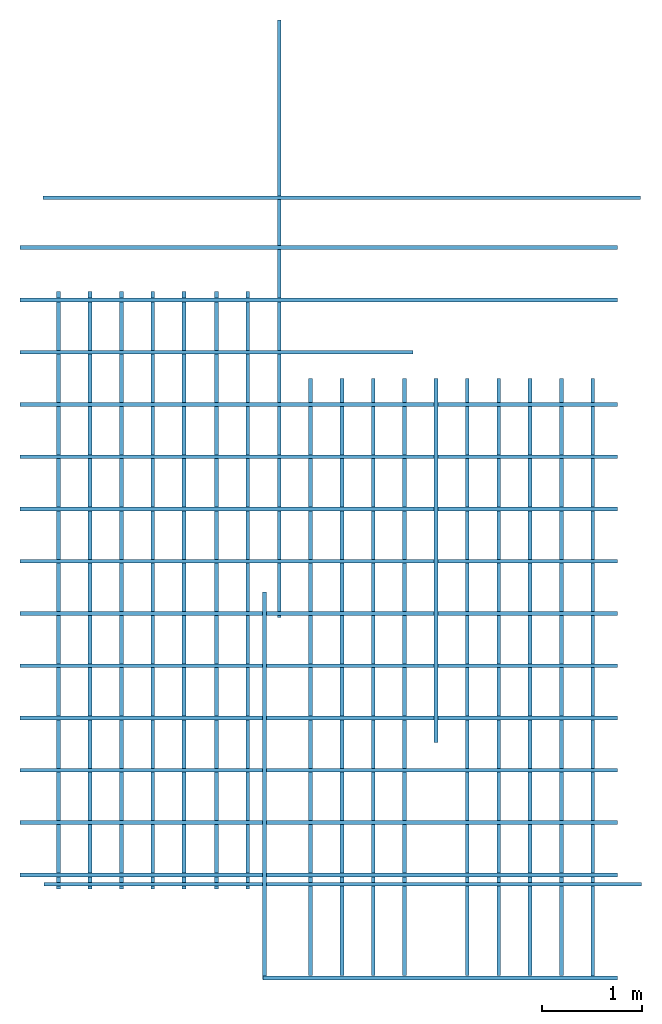
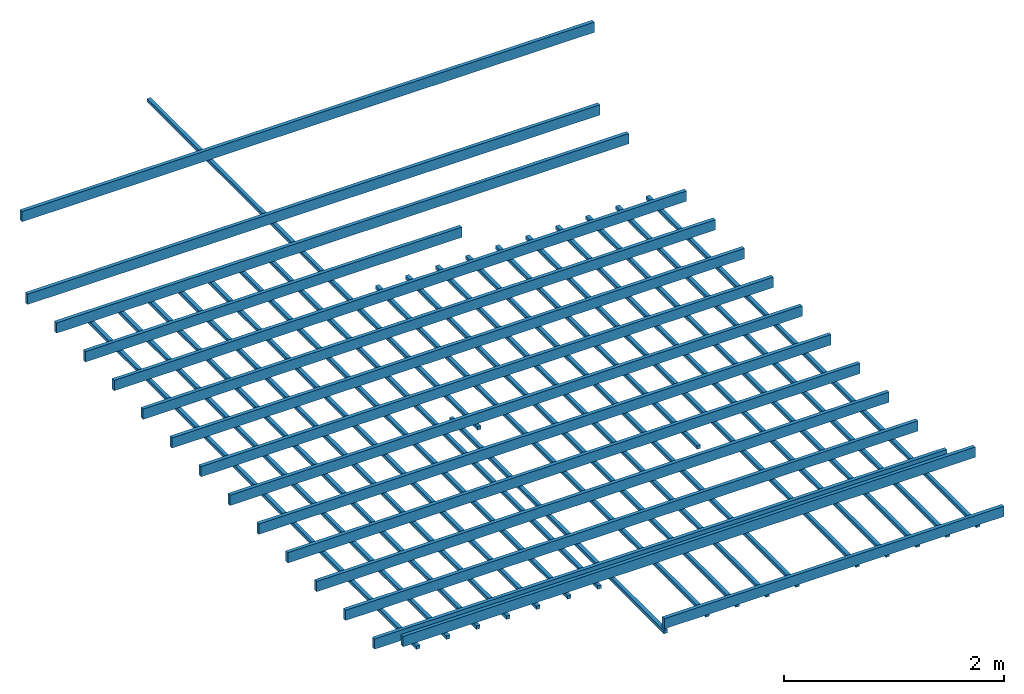
# One storey: 35 beams, 1 element without a shape of its own.
"""IFC4 building model written with IfcOpenShell, lengths in millimetres."""

from ifc_helpers import new_model, entity, si_unit, converted_unit, frame, origin_with_axes, origin_2d_with_axis, place, context, subcontext, project, spatial, line, indexed_curve, rectangle, outline, extrude, material, material_profile, profile_set, profile_usage, type_object, element, aggregate, save


model = new_model("IFC4")

# Units and contexts
model_context = context("Model", 3, precision=1e-05, world=origin_with_axes())
plan_context = context("Plan", 2, precision=1e-05, world=origin_2d_with_axis())
body_context = subcontext(model_context, "Body", "Model", "MODEL_VIEW")
ifc_project = project(units=[si_unit("VOLUMEUNIT", "CUBIC_METRE"), si_unit("LENGTHUNIT", "METRE", prefix="MILLI"), converted_unit("PLANEANGLEUNIT", "degree", entity("IfcReal", 0.0174532925199433), si_unit("PLANEANGLEUNIT", "RADIAN"), dimensions=[0, 0, 0, 0, 0, 0, 0]), si_unit("AREAUNIT", "SQUARE_METRE")], contexts=[model_context, plan_context])

# Site, building, storey
site_placement = place(None, origin_with_axes())
site = spatial("IfcSite", under=ifc_project, at=site_placement)
building_placement = place(site_placement, origin_with_axes())
building = spatial("IfcBuilding", under=site, at=building_placement, Name="Building")
storey_placement = place(building_placement, frame((0.0, 0.0, 2300.00019073486), z_axis=(0.0, 0.0, 1.0), x_axis=(1.0, 0.0, 0.0)))
storey = spatial("IfcBuildingStorey", under=building, at=storey_placement, Name="1-Roof")

# Roof, beams
roof_placement = place(storey_placement, frame((5390.87295532227, 3600.093126297, 19.228458404541), z_axis=(0.0, 0.0, 1.0), x_axis=(1.0, 0.0, 0.0)))
roof = element("IfcRoof", 1, at=roof_placement, inside=storey, Name="Assembly")
ifc_material_1 = material(Name="Timber")
ifc_material_profile_1 = material_profile(ifc_material_1, outline(indexed_curve([(0.0, 0.0), (37.9999987781048, 0.0), (37.9999987781048, 114.000000059605), (0.0, 114.000000059605)], segments=[line(3, 2), line(2, 1), line(1, 4), line(4, 3)], self_intersect=False)))
ifc_profile_set_1 = profile_set([ifc_material_profile_1])
ifc_profile_usage_1 = profile_usage(ifc_profile_set_1, cardinal=5)
beam_type_1 = type_object("IfcBeamType", Name="Timber 38x114", PredefinedType="BEAM", material=ifc_profile_set_1)
beam_1_placement = place(roof_placement, frame((-4166.90635681152, 4951.86591148376, 19.4551944732666), z_axis=(0.999999999999994, -7.54979012640429e-08, 7.54979012640429e-08), x_axis=(7.54979012640431e-08, 0.999999999999997, 7.16093850883224e-15)))
beam_1 = element("IfcBeam", 2, at=beam_1_placement, type_object=beam_type_1, material=ifc_profile_usage_1, Name="Beam", context=body_context, shape_type="SweptSolid", body=[
    extrude(outline(indexed_curve([(0.0, 0.0), (37.9999987781048, 0.0), (37.9999987781048, 114.000000059605), (0.0, 114.000000059605)], segments=[line(3, 2), line(2, 1), line(1, 4), line(4, 3)], self_intersect=False)), origin_with_axes(), (0.0, 0.0, 1.0), 6000.00047683716),
])
ifc_profile_usage_2 = profile_usage(ifc_profile_set_1, cardinal=5)
beam_2_placement = place(roof_placement, frame((-4166.90635681152, 4426.86629295349, 19.4551944732666), z_axis=(0.999999999999994, -7.54979012640429e-08, 7.54979012640429e-08), x_axis=(7.54979012640431e-08, 0.999999999999997, 7.16093850883224e-15)))
beam_2 = element("IfcBeam", 3, at=beam_2_placement, type_object=beam_type_1, material=ifc_profile_usage_2, Name="Beam", context=body_context, shape_type="SweptSolid", body=[
    extrude(outline(indexed_curve([(0.0, 0.0), (37.9999987781048, 0.0), (37.9999987781048, 114.000000059605), (0.0, 114.000000059605)], segments=[line(3, 2), line(2, 1), line(1, 4), line(4, 3)], self_intersect=False)), origin_with_axes(), (0.0, 0.0, 1.0), 6000.00047683716),
])
ifc_profile_usage_3 = profile_usage(ifc_profile_set_1, cardinal=5)
beam_3_placement = place(roof_placement, frame((-4166.90635681152, 3901.86667442322, 19.4551944732666), z_axis=(0.999999999999994, -7.54979012640429e-08, 7.54979012640429e-08), x_axis=(7.54979012640431e-08, 0.999999999999997, 7.16093850883224e-15)))
beam_3 = element("IfcBeam", 4, at=beam_3_placement, type_object=beam_type_1, material=ifc_profile_usage_3, Name="Beam", context=body_context, shape_type="SweptSolid", body=[
    extrude(outline(indexed_curve([(0.0, 0.0), (37.9999987781048, 0.0), (37.9999987781048, 114.000000059605), (0.0, 114.000000059605)], segments=[line(3, 2), line(2, 1), line(1, 4), line(4, 3)], self_intersect=False)), origin_with_axes(), (0.0, 0.0, 1.0), 3947.74819906247),
])
ifc_profile_usage_4 = profile_usage(ifc_profile_set_1, cardinal=5)
beam_4_placement = place(roof_placement, frame((-4166.90635681152, 3376.86705589294, 19.4551944732666), z_axis=(0.999999999999994, -7.54979012640429e-08, 7.54979012640429e-08), x_axis=(7.54979012640431e-08, 0.999999999999997, 7.16093850883224e-15)))
beam_4 = element("IfcBeam", 5, at=beam_4_placement, type_object=beam_type_1, material=ifc_profile_usage_4, Name="Beam", context=body_context, shape_type="SweptSolid", body=[
    extrude(outline(indexed_curve([(0.0, 0.0), (37.9999987781048, 0.0), (37.9999987781048, 114.000000059605), (0.0, 114.000000059605)], segments=[line(3, 2), line(2, 1), line(1, 4), line(4, 3)], self_intersect=False)), origin_with_axes(), (0.0, 0.0, 1.0), 6000.00047683716),
])
ifc_profile_usage_5 = profile_usage(ifc_profile_set_1, cardinal=5)
beam_5_placement = place(roof_placement, frame((-4166.90635681152, 2851.86743736267, 19.4551944732666), z_axis=(0.999999999999994, -7.54979012640429e-08, 7.54979012640429e-08), x_axis=(7.54979012640431e-08, 0.999999999999997, 7.16093850883224e-15)))
beam_5 = element("IfcBeam", 6, at=beam_5_placement, type_object=beam_type_1, material=ifc_profile_usage_5, Name="Beam", context=body_context, shape_type="SweptSolid", body=[
    extrude(outline(indexed_curve([(0.0, 0.0), (37.9999987781048, 0.0), (37.9999987781048, 114.000000059605), (0.0, 114.000000059605)], segments=[line(3, 2), line(2, 1), line(1, 4), line(4, 3)], self_intersect=False)), origin_with_axes(), (0.0, 0.0, 1.0), 6000.00047683716),
])
ifc_profile_usage_6 = profile_usage(ifc_profile_set_1, cardinal=5)
beam_6_placement = place(roof_placement, frame((-4166.90635681152, 2326.8678188324, 19.4551944732666), z_axis=(0.999999999999994, -7.54979012640429e-08, 7.54979012640429e-08), x_axis=(7.54979012640431e-08, 0.999999999999997, 7.16093850883224e-15)))
beam_6 = element("IfcBeam", 7, at=beam_6_placement, type_object=beam_type_1, material=ifc_profile_usage_6, Name="Beam", context=body_context, shape_type="SweptSolid", body=[
    extrude(outline(indexed_curve([(0.0, 0.0), (37.9999987781048, 0.0), (37.9999987781048, 114.000000059605), (0.0, 114.000000059605)], segments=[line(3, 2), line(2, 1), line(1, 4), line(4, 3)], self_intersect=False)), origin_with_axes(), (0.0, 0.0, 1.0), 6000.00047683716),
])
ifc_profile_usage_7 = profile_usage(ifc_profile_set_1, cardinal=5)
beam_7_placement = place(roof_placement, frame((-4166.90635681152, 1801.86820030212, 19.4551944732666), z_axis=(0.999999999999994, -7.54979012640429e-08, 7.54979012640429e-08), x_axis=(7.54979012640431e-08, 0.999999999999997, 7.16093850883224e-15)))
beam_7 = element("IfcBeam", 8, at=beam_7_placement, type_object=beam_type_1, material=ifc_profile_usage_7, Name="Beam", context=body_context, shape_type="SweptSolid", body=[
    extrude(outline(indexed_curve([(0.0, 0.0), (37.9999987781048, 0.0), (37.9999987781048, 114.000000059605), (0.0, 114.000000059605)], segments=[line(3, 2), line(2, 1), line(1, 4), line(4, 3)], self_intersect=False)), origin_with_axes(), (0.0, 0.0, 1.0), 6000.00047683716),
])
ifc_profile_usage_8 = profile_usage(ifc_profile_set_1, cardinal=5)
beam_8_placement = place(roof_placement, frame((-4166.90635681152, 1276.86858177185, 19.4551944732666), z_axis=(0.999999999999994, -7.54979012640429e-08, 7.54979012640429e-08), x_axis=(7.54979012640431e-08, 0.999999999999997, 7.16093850883224e-15)))
beam_8 = element("IfcBeam", 9, at=beam_8_placement, type_object=beam_type_1, material=ifc_profile_usage_8, Name="Beam", context=body_context, shape_type="SweptSolid", body=[
    extrude(outline(indexed_curve([(0.0, 0.0), (37.9999987781048, 0.0), (37.9999987781048, 114.000000059605), (0.0, 114.000000059605)], segments=[line(3, 2), line(2, 1), line(1, 4), line(4, 3)], self_intersect=False)), origin_with_axes(), (0.0, 0.0, 1.0), 6000.00047683716),
])
ifc_profile_usage_9 = profile_usage(ifc_profile_set_1, cardinal=5)
beam_9_placement = place(roof_placement, frame((-4166.90635681152, 751.868963241577, 19.4551944732666), z_axis=(0.999999999999994, -7.54979012640429e-08, 7.54979012640429e-08), x_axis=(7.54979012640431e-08, 0.999999999999997, 7.16093850883224e-15)))
beam_9 = element("IfcBeam", 10, at=beam_9_placement, type_object=beam_type_1, material=ifc_profile_usage_9, Name="Beam", context=body_context, shape_type="SweptSolid", body=[
    extrude(outline(indexed_curve([(0.0, 0.0), (37.9999987781048, 0.0), (37.9999987781048, 114.000000059605), (0.0, 114.000000059605)], segments=[line(3, 2), line(2, 1), line(1, 4), line(4, 3)], self_intersect=False)), origin_with_axes(), (0.0, 0.0, 1.0), 6000.00047683716),
])
ifc_profile_usage_10 = profile_usage(ifc_profile_set_1, cardinal=5)
beam_10_placement = place(roof_placement, frame((-4166.90635681152, 226.869344711304, 19.4551944732666), z_axis=(0.999999999999994, -7.54979012640429e-08, 7.54979012640429e-08), x_axis=(7.54979012640431e-08, 0.999999999999997, 7.16093850883224e-15)))
beam_10 = element("IfcBeam", 11, at=beam_10_placement, type_object=beam_type_1, material=ifc_profile_usage_10, Name="Beam", context=body_context, shape_type="SweptSolid", body=[
    extrude(outline(indexed_curve([(0.0, 0.0), (37.9999987781048, 0.0), (37.9999987781048, 114.000000059605), (0.0, 114.000000059605)], segments=[line(3, 2), line(2, 1), line(1, 4), line(4, 3)], self_intersect=False)), origin_with_axes(), (0.0, 0.0, 1.0), 6000.00047683716),
])
ifc_profile_usage_11 = profile_usage(ifc_profile_set_1, cardinal=5)
beam_11_placement = place(roof_placement, frame((-4166.90635681152, -298.13027381897, 19.4551944732666), z_axis=(0.999999999999994, -7.54979012640429e-08, 7.54979012640429e-08), x_axis=(7.54979012640431e-08, 0.999999999999997, 7.16093850883224e-15)))
beam_11 = element("IfcBeam", 12, at=beam_11_placement, type_object=beam_type_1, material=ifc_profile_usage_11, Name="Beam", context=body_context, shape_type="SweptSolid", body=[
    extrude(outline(indexed_curve([(0.0, 0.0), (37.9999987781048, 0.0), (37.9999987781048, 114.000000059605), (0.0, 114.000000059605)], segments=[line(3, 2), line(2, 1), line(1, 4), line(4, 3)], self_intersect=False)), origin_with_axes(), (0.0, 0.0, 1.0), 6000.00047683716),
])
ifc_profile_usage_12 = profile_usage(ifc_profile_set_1, cardinal=5)
beam_12_placement = place(roof_placement, frame((-4166.90635681152, -823.129892349243, 19.4551944732666), z_axis=(0.999999999999994, -7.54979012640429e-08, 7.54979012640429e-08), x_axis=(7.54979012640431e-08, 0.999999999999997, 7.16093850883224e-15)))
beam_12 = element("IfcBeam", 13, at=beam_12_placement, type_object=beam_type_1, material=ifc_profile_usage_12, Name="Beam", context=body_context, shape_type="SweptSolid", body=[
    extrude(outline(indexed_curve([(0.0, 0.0), (37.9999987781048, 0.0), (37.9999987781048, 114.000000059605), (0.0, 114.000000059605)], segments=[line(3, 2), line(2, 1), line(1, 4), line(4, 3)], self_intersect=False)), origin_with_axes(), (0.0, 0.0, 1.0), 6000.00047683716),
])
ifc_profile_usage_13 = profile_usage(ifc_profile_set_1, cardinal=5)
beam_13_placement = place(roof_placement, frame((-4166.90635681152, -1348.12951087952, 19.4551944732666), z_axis=(0.999999999999994, -7.54979012640429e-08, 7.54979012640429e-08), x_axis=(7.54979012640431e-08, 0.999999999999997, 7.16093850883224e-15)))
beam_13 = element("IfcBeam", 14, at=beam_13_placement, type_object=beam_type_1, material=ifc_profile_usage_13, Name="Beam", context=body_context, shape_type="SweptSolid", body=[
    extrude(outline(indexed_curve([(0.0, 0.0), (37.9999987781048, 0.0), (37.9999987781048, 114.000000059605), (0.0, 114.000000059605)], segments=[line(3, 2), line(2, 1), line(1, 4), line(4, 3)], self_intersect=False)), origin_with_axes(), (0.0, 0.0, 1.0), 6000.00047683716),
])
ifc_profile_usage_14 = profile_usage(ifc_profile_set_1, cardinal=5)
beam_14_placement = place(roof_placement, frame((-3923.62546920776, -1443.51387023926, 19.4551944732666), z_axis=(0.999999999999994, -7.54979012640429e-08, 7.54979012640429e-08), x_axis=(7.54979012640431e-08, 0.999999999999997, 7.16093850883224e-15)))
beam_14 = element("IfcBeam", 15, at=beam_14_placement, type_object=beam_type_1, material=ifc_profile_usage_14, Name="Beam", context=body_context, shape_type="SweptSolid", body=[
    extrude(outline(indexed_curve([(0.0, 0.0), (37.9999987781048, 0.0), (37.9999987781048, 114.000000059605), (0.0, 114.000000059605)], segments=[line(3, 2), line(2, 1), line(1, 4), line(4, 3)], self_intersect=False)), origin_with_axes(), (0.0, 0.0, 1.0), 6000.00047683716),
])
ifc_profile_usage_15 = profile_usage(ifc_profile_set_1, cardinal=5)
beam_15_placement = place(roof_placement, frame((-1727.8265953064, -2385.15472412109, 19.4554328918457), z_axis=(0.999999999999994, -7.54979012640429e-08, 7.54979012640429e-08), x_axis=(7.54979012640431e-08, 0.999999999999997, 7.16093850883224e-15)))
beam_15 = element("IfcBeam", 16, at=beam_15_placement, type_object=beam_type_1, material=ifc_profile_usage_15, Name="Beam", context=body_context, shape_type="SweptSolid", body=[
    extrude(outline(indexed_curve([(0.0, 0.0), (37.9999987781048, 0.0), (37.9999987781048, 114.000000059605), (0.0, 114.000000059605)], segments=[line(3, 2), line(2, 1), line(1, 4), line(4, 3)], self_intersect=False)), origin_with_axes(), (0.0, 0.0, 1.0), 3560.92076684722),
])
ifc_profile_usage_16 = profile_usage(ifc_profile_set_1, cardinal=5)
beam_16_placement = place(roof_placement, frame((-3935.29033660889, 5451.86591148376, 551.745414733887), z_axis=(0.999999999999994, -7.54979012640429e-08, 7.54979012640429e-08), x_axis=(7.54979012640431e-08, 0.999999999999997, 7.16093850883224e-15)))
beam_16 = element("IfcBeam", 17, at=beam_16_placement, type_object=beam_type_1, material=ifc_profile_usage_16, Name="Beam", context=body_context, shape_type="SweptSolid", body=[
    extrude(outline(indexed_curve([(0.0, 0.0), (37.9999987781048, 0.0), (37.9999987781048, 114.000000059605), (0.0, 114.000000059605)], segments=[line(3, 2), line(2, 1), line(1, 4), line(4, 3)], self_intersect=False)), origin_with_axes(), (0.0, 0.0, 1.0), 6000.00047683716),
])
ifc_material_2 = material(Name="-test 240326")
ifc_material_profile_2 = material_profile(ifc_material_2, rectangle(XDim=38.0, YDim=38.0))
ifc_profile_set_2 = profile_set([ifc_material_profile_2])
ifc_profile_usage_17 = profile_usage(ifc_profile_set_2, cardinal=5)
beam_type_2 = type_object("IfcBeamType", Name="Timber 38x38x600", PredefinedType="BEAM", material=ifc_profile_set_2)
beam_17_placement = place(roof_placement, frame((-3778.82635593415, -1468.94192695618, -19.228458404541), z_axis=(1.50995802528084e-07, 0.999999999999986, 7.54979012640422e-08), x_axis=(-0.999999999999989, 1.50995802528085e-07, 7.16093766179923e-15)))
beam_17 = element("IfcBeam", 18, at=beam_17_placement, type_object=beam_type_2, material=ifc_profile_usage_17, Name="Beam", context=body_context, shape_type="SweptSolid", body=[
    extrude(rectangle(XDim=38.0, YDim=38.0), origin_with_axes(), (0.0, 0.0, 1.0), 6000.00047683716),
])
ifc_profile_usage_18 = profile_usage(ifc_profile_set_2, cardinal=5)
beam_18_placement = place(roof_placement, frame((-3463.82629871369, -1468.94192695618, -19.228458404541), z_axis=(1.50995802528084e-07, 0.999999999999986, 7.54979012640422e-08), x_axis=(-0.999999999999989, 1.50995802528085e-07, 7.16093766179923e-15)))
beam_18 = element("IfcBeam", 19, at=beam_18_placement, type_object=beam_type_2, material=ifc_profile_usage_18, Name="Beam", context=body_context, shape_type="SweptSolid", body=[
    extrude(rectangle(XDim=38.0, YDim=38.0), origin_with_axes(), (0.0, 0.0, 1.0), 6000.00047683716),
])
ifc_profile_usage_19 = profile_usage(ifc_profile_set_2, cardinal=5)
beam_19_placement = place(roof_placement, frame((-3148.82636070252, -1468.94192695618, -19.228458404541), z_axis=(1.50995802528084e-07, 0.999999999999986, 7.54979012640422e-08), x_axis=(-0.999999999999989, 1.50995802528085e-07, 7.16093766179923e-15)))
beam_19 = element("IfcBeam", 20, at=beam_19_placement, type_object=beam_type_2, material=ifc_profile_usage_19, Name="Beam", context=body_context, shape_type="SweptSolid", body=[
    extrude(rectangle(XDim=38.0, YDim=38.0), origin_with_axes(), (0.0, 0.0, 1.0), 6000.00047683716),
])
ifc_profile_usage_20 = profile_usage(ifc_profile_set_2, cardinal=5)
beam_20_placement = place(roof_placement, frame((-2833.82630348206, -1468.94192695618, -19.228458404541), z_axis=(1.50995802528084e-07, 0.999999999999986, 7.54979012640422e-08), x_axis=(-0.999999999999989, 1.50995802528085e-07, 7.16093766179923e-15)))
beam_20 = element("IfcBeam", 21, at=beam_20_placement, type_object=beam_type_2, material=ifc_profile_usage_20, Name="Beam", context=body_context, shape_type="SweptSolid", body=[
    extrude(rectangle(XDim=38.0, YDim=38.0), origin_with_axes(), (0.0, 0.0, 1.0), 6000.00047683716),
])
ifc_profile_usage_21 = profile_usage(ifc_profile_set_2, cardinal=5)
beam_21_placement = place(roof_placement, frame((-2518.82648468018, -1468.94192695618, -19.228458404541), z_axis=(1.50995802528084e-07, 0.999999999999986, 7.54979012640422e-08), x_axis=(-0.999999999999989, 1.50995802528085e-07, 7.16093766179923e-15)))
beam_21 = element("IfcBeam", 22, at=beam_21_placement, type_object=beam_type_2, material=ifc_profile_usage_21, Name="Beam", context=body_context, shape_type="SweptSolid", body=[
    extrude(rectangle(XDim=38.0, YDim=38.0), origin_with_axes(), (0.0, 0.0, 1.0), 6000.00047683716),
])
ifc_profile_usage_22 = profile_usage(ifc_profile_set_2, cardinal=5)
beam_22_placement = place(roof_placement, frame((-2193.82643699646, -1468.94192695618, -19.228458404541), z_axis=(1.50995802528084e-07, 0.999999999999986, 7.54979012640422e-08), x_axis=(-0.999999999999989, 1.50995802528085e-07, 7.16093766179923e-15)))
beam_22 = element("IfcBeam", 23, at=beam_22_placement, type_object=beam_type_2, material=ifc_profile_usage_22, Name="Beam", context=body_context, shape_type="SweptSolid", body=[
    extrude(rectangle(XDim=38.0, YDim=38.0), origin_with_axes(), (0.0, 0.0, 1.0), 6000.00047683716),
])
ifc_profile_usage_23 = profile_usage(ifc_profile_set_2, cardinal=5)
beam_23_placement = place(roof_placement, frame((-1878.82661819458, -1468.94192695618, -19.228458404541), z_axis=(1.50995802528084e-07, 0.999999999999986, 7.54979012640422e-08), x_axis=(-0.999999999999989, 1.50995802528085e-07, 7.16093766179923e-15)))
beam_23 = element("IfcBeam", 24, at=beam_23_placement, type_object=beam_type_2, material=ifc_profile_usage_23, Name="Beam", context=body_context, shape_type="SweptSolid", body=[
    extrude(rectangle(XDim=38.0, YDim=38.0), origin_with_axes(), (0.0, 0.0, 1.0), 6000.00047683716),
])
ifc_profile_usage_24 = profile_usage(ifc_profile_set_2, cardinal=5)
beam_24_placement = place(roof_placement, frame((-1709.82646942139, -2378.94213199616, -19.228458404541), z_axis=(1.50995802528084e-07, 0.999999999999986, 7.54979012640422e-08), x_axis=(-0.999999999999989, 1.50995802528085e-07, 7.16093766179923e-15)))
beam_24 = element("IfcBeam", 25, at=beam_24_placement, type_object=beam_type_2, material=ifc_profile_usage_24, Name="Beam", context=body_context, shape_type="SweptSolid", body=[
    extrude(rectangle(XDim=38.0, YDim=38.0), origin_with_axes(), (0.0, 0.0, 1.0), 3892.605809689),
])
ifc_profile_usage_25 = profile_usage(ifc_profile_set_2, cardinal=5)
beam_25_placement = place(roof_placement, frame((-1563.82656097413, 1257.04550743103, -19.228458404541), z_axis=(1.50995802528084e-07, 0.999999999999986, 7.54979012640422e-08), x_axis=(-0.999999999999989, 1.50995802528085e-07, 1.00485924106347e-14)))
beam_25 = element("IfcBeam", 26, at=beam_25_placement, type_object=beam_type_2, material=ifc_profile_usage_25, Name="Beam", context=body_context, shape_type="SweptSolid", body=[
    extrude(rectangle(XDim=38.0, YDim=38.0), origin_with_axes(), (0.0, 0.0, 1.0), 6000.00047683716),
])
ifc_profile_usage_26 = profile_usage(ifc_profile_set_2, cardinal=5)
beam_26_placement = place(roof_placement, frame((-1248.82650375367, -2342.00036525727, -19.228458404541), z_axis=(1.50995802528084e-07, 0.999999999999986, 7.54979012640422e-08), x_axis=(-0.999999999999989, 1.50995802528085e-07, 7.16093766179923e-15)))
beam_26 = element("IfcBeam", 27, at=beam_26_placement, type_object=beam_type_2, material=ifc_profile_usage_26, Name="Beam", context=body_context, shape_type="SweptSolid", body=[
    extrude(rectangle(XDim=38.0, YDim=38.0), origin_with_axes(), (0.0, 0.0, 1.0), 6000.00047683716),
])
ifc_profile_usage_27 = profile_usage(ifc_profile_set_2, cardinal=5)
beam_27_placement = place(roof_placement, frame((-933.826446533206, -2342.00036525727, -19.228458404541), z_axis=(1.50995802528084e-07, 0.999999999999986, 7.54979012640422e-08), x_axis=(-0.999999999999989, 1.50995802528085e-07, 7.16093766179923e-15)))
beam_27 = element("IfcBeam", 28, at=beam_27_placement, type_object=beam_type_2, material=ifc_profile_usage_27, Name="Beam", context=body_context, shape_type="SweptSolid", body=[
    extrude(rectangle(XDim=38.0, YDim=38.0), origin_with_axes(), (0.0, 0.0, 1.0), 6000.00047683716),
])
ifc_profile_usage_28 = profile_usage(ifc_profile_set_2, cardinal=5)
beam_28_placement = place(roof_placement, frame((-618.826389312746, -2342.00036525727, -19.228458404541), z_axis=(1.50995802528084e-07, 0.999999999999986, 7.54979012640422e-08), x_axis=(-0.999999999999989, 1.50995802528085e-07, 7.16093766179923e-15)))
beam_28 = element("IfcBeam", 29, at=beam_28_placement, type_object=beam_type_2, material=ifc_profile_usage_28, Name="Beam", context=body_context, shape_type="SweptSolid", body=[
    extrude(rectangle(XDim=38.0, YDim=38.0), origin_with_axes(), (0.0, 0.0, 1.0), 6000.00047683716),
])
ifc_profile_usage_29 = profile_usage(ifc_profile_set_2, cardinal=5)
beam_29_placement = place(roof_placement, frame((-303.826332092286, -2342.00036525727, -19.228458404541), z_axis=(1.50995802528084e-07, 0.999999999999986, 7.54979012640422e-08), x_axis=(-0.999999999999989, 1.50995802528085e-07, 7.16093766179923e-15)))
beam_29 = element("IfcBeam", 30, at=beam_29_placement, type_object=beam_type_2, material=ifc_profile_usage_29, Name="Beam", context=body_context, shape_type="SweptSolid", body=[
    extrude(rectangle(XDim=38.0, YDim=38.0), origin_with_axes(), (0.0, 0.0, 1.0), 6000.00047683716),
])
ifc_profile_usage_30 = profile_usage(ifc_profile_set_2, cardinal=5)
beam_30_placement = place(roof_placement, frame((11.174201965332, -0.000238418579101562, -19.2282199859619), z_axis=(1.50995802528084e-07, 0.999999999999986, 7.54979012640422e-08), x_axis=(-0.999999999999989, 1.50995802528085e-07, 1.00485924106347e-14)))
beam_30 = element("IfcBeam", 31, at=beam_30_placement, type_object=beam_type_2, material=ifc_profile_usage_30, Name="Beam", context=body_context, shape_type="SweptSolid", body=[
    extrude(rectangle(XDim=38.0, YDim=38.0), origin_with_axes(), (0.0, 0.0, 1.0), 3658.00042922333),
])
ifc_profile_usage_31 = profile_usage(ifc_profile_set_2, cardinal=5)
beam_31_placement = place(roof_placement, frame((326.173782348635, -2342.00036525727, -19.228458404541), z_axis=(1.50995802528084e-07, 0.999999999999986, 7.54979012640422e-08), x_axis=(-0.999999999999989, 1.50995802528085e-07, 7.16093766179923e-15)))
beam_31 = element("IfcBeam", 32, at=beam_31_placement, type_object=beam_type_2, material=ifc_profile_usage_31, Name="Beam", context=body_context, shape_type="SweptSolid", body=[
    extrude(rectangle(XDim=38.0, YDim=38.0), origin_with_axes(), (0.0, 0.0, 1.0), 6000.00047683716),
])
ifc_profile_usage_32 = profile_usage(ifc_profile_set_2, cardinal=5)
beam_32_placement = place(roof_placement, frame((641.173839569094, -2342.00036525727, -19.228458404541), z_axis=(1.50995802528084e-07, 0.999999999999986, 7.54979012640422e-08), x_axis=(-0.999999999999989, 1.50995802528085e-07, 7.16093766179923e-15)))
beam_32 = element("IfcBeam", 33, at=beam_32_placement, type_object=beam_type_2, material=ifc_profile_usage_32, Name="Beam", context=body_context, shape_type="SweptSolid", body=[
    extrude(rectangle(XDim=38.0, YDim=38.0), origin_with_axes(), (0.0, 0.0, 1.0), 6000.00047683716),
])
ifc_profile_usage_33 = profile_usage(ifc_profile_set_2, cardinal=5)
beam_33_placement = place(roof_placement, frame((956.173896789554, -2342.00036525727, -19.228458404541), z_axis=(1.50995802528084e-07, 0.999999999999986, 7.54979012640422e-08), x_axis=(-0.999999999999989, 1.50995802528085e-07, 7.16093766179923e-15)))
beam_33 = element("IfcBeam", 34, at=beam_33_placement, type_object=beam_type_2, material=ifc_profile_usage_33, Name="Beam", context=body_context, shape_type="SweptSolid", body=[
    extrude(rectangle(XDim=38.0, YDim=38.0), origin_with_axes(), (0.0, 0.0, 1.0), 6000.00047683716),
])
ifc_profile_usage_34 = profile_usage(ifc_profile_set_2, cardinal=5)
beam_34_placement = place(roof_placement, frame((1271.17395401001, -2342.00036525727, -19.228458404541), z_axis=(1.50995802528084e-07, 0.999999999999986, 7.54979012640422e-08), x_axis=(-0.999999999999989, 1.50995802528085e-07, 7.16093766179923e-15)))
beam_34 = element("IfcBeam", 35, at=beam_34_placement, type_object=beam_type_2, material=ifc_profile_usage_34, Name="Beam", context=body_context, shape_type="SweptSolid", body=[
    extrude(rectangle(XDim=38.0, YDim=38.0), origin_with_axes(), (0.0, 0.0, 1.0), 6000.00047683716),
])
ifc_profile_usage_35 = profile_usage(ifc_profile_set_2, cardinal=5)
beam_35_placement = place(roof_placement, frame((1586.17401123046, -2343.73879432679, -19.228458404541), z_axis=(1.50995802528084e-07, 0.999999999999986, 7.54979012640422e-08), x_axis=(-0.999999999999989, 1.50995802528085e-07, 7.16093766179923e-15)))
beam_35 = element("IfcBeam", 36, at=beam_35_placement, type_object=beam_type_2, material=ifc_profile_usage_35, Name="Beam", context=body_context, shape_type="SweptSolid", body=[
    extrude(rectangle(XDim=38.0, YDim=38.0), origin_with_axes(), (0.0, 0.0, 1.0), 6000.00047683716),
])
aggregate(roof, [beam_17, beam_18, beam_19, beam_20, beam_21, beam_22, beam_23, beam_24, beam_25, beam_26, beam_27, beam_28, beam_29, beam_30, beam_31, beam_32, beam_33, beam_34, beam_35, beam_1, beam_2, beam_3, beam_4, beam_5, beam_6, beam_7, beam_8, beam_9, beam_10, beam_11, beam_12, beam_13, beam_14, beam_15, beam_16])

save(model, "model.ifc")
